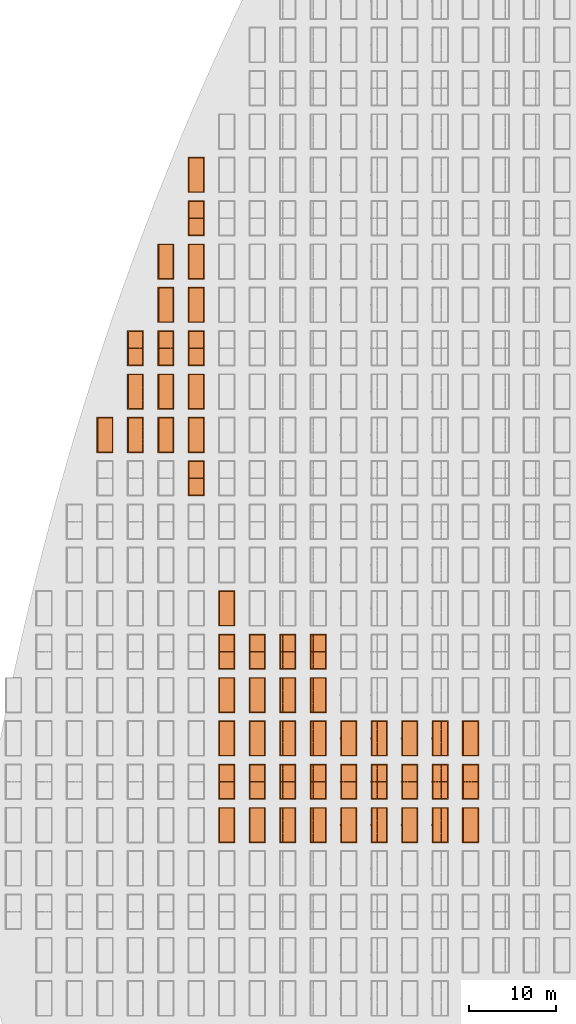
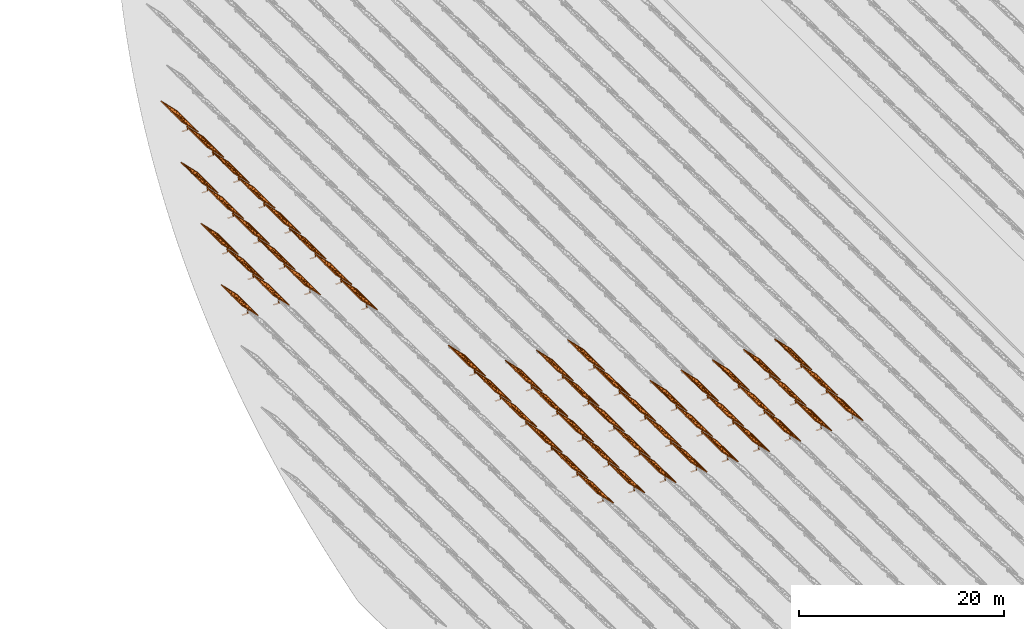
# One storey, part 22 of 39: 53 proxies.
"""IFC2X3 building model written with IfcOpenShell, lengths in millimetres."""

from ifc_helpers import new_model, entity, si_unit, converted_unit, derived_unit, direction, frame, frame_2d, origin, origin_2d_with_axis, place, context, subcontext, project, spatial, polyline, rectangle, outline, extrude, source, transform, mapped, material, material_list, element, save


model = new_model("IFC2X3")

# Units and contexts
model_context = context("Model", 3, precision=1e-06, world=origin(), true_north=direction((2.0, 6.12303176911189e-17, 1.0)))
context_of_model = context(None, 3, precision=1e-06, world=origin(), true_north=direction((2.0, 6.12303176911189e-17, 1.0)))
body_context = subcontext(model_context, "Body", "Model", "MODEL_VIEW")
ifc_project = project(units=[si_unit("LENGTHUNIT", "METRE", prefix="MILLI"), si_unit("AREAUNIT", "SQUARE_METRE", prefix="MILLI"), si_unit("VOLUMEUNIT", "CUBIC_METRE", prefix="MILLI"), converted_unit("PLANEANGLEUNIT", "DEGREE", entity("IfcRatioMeasure", 0.0174532925199433), si_unit("PLANEANGLEUNIT", "RADIAN"), dimensions=[0, 0, 0, 0, 0, 0, 0]), si_unit("MASSUNIT", "GRAM", prefix="KILO"), si_unit("TIMEUNIT", "SECOND"), si_unit("THERMODYNAMICTEMPERATUREUNIT", "KELVIN"), derived_unit("THERMALTRANSMITTANCEUNIT", [(si_unit("MASSUNIT", "GRAM", prefix="KILO"), 1), (si_unit("THERMODYNAMICTEMPERATUREUNIT", "KELVIN"), -1), (si_unit("TIMEUNIT", "SECOND"), -3)]), derived_unit("VOLUMETRICFLOWRATEUNIT", [(si_unit("LENGTHUNIT", "METRE"), 3), (si_unit("TIMEUNIT", "SECOND"), -1)])], contexts=[model_context, context_of_model])

# Site, building, storey
site_placement = place(None, origin())
site = spatial("IfcSite", under=ifc_project, at=site_placement, CompositionType="ELEMENT")
building_placement = place(site_placement, origin())
building = spatial("IfcBuilding", under=site, at=building_placement, CompositionType="ELEMENT")
storey_placement = place(building_placement, frame((0.0, 0.0, 4000.0)))
storey = spatial("IfcBuildingStorey", under=building, at=storey_placement, Name="Level 2", CompositionType="ELEMENT", Elevation=4000.0)

# Proxies
ifc_material_1 = material(Name="Stand-Steel")
ifc_material_2 = material(Name="Aluminium")
ifc_material_3 = material(Name="Glass")
ifc_material_list_1 = material_list([ifc_material_1, ifc_material_2, ifc_material_3])
shared_shape = source(origin(), body_context, "Body", "SweptSolid", [
    extrude(outline(polyline([(-629.526235435404, -220.0), (329.763117717702, -220.0), (329.763117717703, 410.0), (299.763117717703, 410.0), (299.763117717702, -190.0), (-629.526235435404, -190.0), (-629.526235435404, -220.0)])), frame((-190.00003127179, -100.0, 299.763117717707), z_axis=(0.0, 1.0, 0.0), x_axis=(0.0, 0.0, -1.0)), (0.0, 0.0, 1.0), 200.0),
    extrude(rectangle(XDim=20.0000000000001, YDim=200.0, at=frame_2d((0.0, -7.105427357601e-14), x_axis=(0.0, 1.0))), frame((-7.07109908365613, 0.0, 922.21828534124), z_axis=(-0.70710678118654, 0.0, 0.707106781186555), x_axis=(0.0, 1.0, 0.0)), (0.0, 0.0, 1.0), 2600.0),
    extrude(rectangle(XDim=24.9999999999997, YDim=24.9999999999999, at=frame_2d((2.87769807982841e-13, -9.50350909079134e-14), x_axis=(1.0, 0.0))), frame((-1449.56292018118, -1950.0, 2449.57494522722), z_axis=(0.0, 1.0, 0.0), x_axis=(-0.707106781186548, 0.0, -0.707106781186548)), (0.0, 0.0, 1.0), 3900.0),
    extrude(rectangle(XDim=24.9999999999999, YDim=25.0000000000001, at=origin_2d_with_axis()), frame((-1096.0095295879, -1950.0, 2096.02155463395), z_axis=(0.0, 1.0, 0.0), x_axis=(-0.707106781186542, 0.0, -0.707106781186553)), (0.0, 0.0, 1.0), 3900.0),
    extrude(rectangle(XDim=24.9999999999999, YDim=25.0000000000001, at=origin_2d_with_axis()), frame((-742.456138994631, -1950.0, 1742.46816404067), z_axis=(0.0, 1.0, 0.0), x_axis=(-0.707106781186542, 0.0, -0.707106781186553)), (0.0, 0.0, 1.0), 3900.0),
    extrude(rectangle(XDim=25.0, YDim=24.9999999999997, at=frame_2d((-7.19424519957101e-14, 1.19904086659517e-13), x_axis=(1.0, 0.0))), frame((-388.902748401358, -1950.0, 1388.9147734474), z_axis=(0.0, 1.0, 0.0), x_axis=(-0.707106781186545, 0.0, -0.70710678118655)), (0.0, 0.0, 1.0), 3900.0),
    extrude(rectangle(XDim=25.0000000000002, YDim=25.0, at=frame_2d((1.35891298214119e-13, 6.21724893790088e-15), x_axis=(0.0, 1.0))), frame((-35.3553703311048, 1500.0, 1035.35537033109), z_axis=(-0.707106781186544, 0.0, 0.707106781186551), x_axis=(0.0, 1.0, 0.0)), (0.0, 0.0, 1.0), 2440.0),
    extrude(rectangle(XDim=25.0000000000002, YDim=25.0, at=frame_2d((0.0, 1.77635683940025e-15), x_axis=(0.0, 1.0))), frame((-35.3553703311059, 1000.0, 1035.35537033109), z_axis=(-0.707106781186546, 0.0, 0.707106781186549), x_axis=(0.0, 1.0, 0.0)), (0.0, 0.0, 1.0), 2440.0),
    extrude(rectangle(XDim=25.0000000000002, YDim=25.0, at=frame_2d((0.0, 8.43769498715119e-14), x_axis=(0.0, 1.0))), frame((-26.5165355662756, 0.0, 1044.19420509593), z_axis=(-0.707106781186546, 0.0, 0.707106781186549), x_axis=(0.0, -1.0, 0.0)), (0.0, 0.0, 1.0), 2440.0),
    extrude(rectangle(XDim=25.0000000000002, YDim=25.0, at=frame_2d((0.0, 8.88178419700125e-16), x_axis=(0.0, 1.0))), frame((-35.3553703311065, 500.0, 1035.35537033109), z_axis=(-0.707106781186546, 0.0, 0.707106781186549), x_axis=(0.0, 1.0, 0.0)), (0.0, 0.0, 1.0), 2440.0),
    extrude(rectangle(XDim=25.0000000000002, YDim=25.0, at=frame_2d((0.0, 8.88178419700125e-16), x_axis=(0.0, 1.0))), frame((-35.3553703311086, -500.0, 1035.35537033109), z_axis=(-0.707106781186546, 0.0, 0.707106781186549), x_axis=(0.0, 1.0, 0.0)), (0.0, 0.0, 1.0), 2440.0),
    extrude(rectangle(XDim=25.0000000000002, YDim=25.0, at=frame_2d((0.0, 8.88178419700125e-16), x_axis=(0.0, 1.0))), frame((-35.3553703311095, -1000.0, 1035.35537033109), z_axis=(-0.707106781186546, 0.0, 0.707106781186549), x_axis=(0.0, 1.0, 0.0)), (0.0, 0.0, 1.0), 2440.0),
    extrude(rectangle(XDim=25.0000000000002, YDim=25.0, at=frame_2d((1.35891298214119e-13, 1.77635683940025e-15), x_axis=(0.0, 1.0))), frame((-35.3553703311107, -1500.0, 1035.35537033109), z_axis=(-0.707106781186546, 0.0, 0.707106781186549), x_axis=(0.0, 1.0, 0.0)), (0.0, 0.0, 1.0), 2440.0),
    extrude(rectangle(XDim=2400.0, YDim=11.9999999999994, at=frame_2d((-1.13686837721616e-13, 2.02948768901479e-13), x_axis=(1.0, 0.0))), frame((-883.883507754966, -1950.0, 1883.88350775495), z_axis=(0.0, 1.0, 0.0), x_axis=(0.707106781186546, 0.0, -0.707106781186549)), (0.0, 0.0, 1.0), 3900.0),
    extrude(outline(polyline([(-2050.0, -1300.0), (2050.0, -1300.0), (2050.0, 1300.0), (-2050.0, 1300.0), (-2050.0, -1300.0)]), holes=[polyline([(1950.0, -1200.0), (-1950.0, -1200.0), (-1950.0, 1200.0), (1950.0, 1200.0), (1950.0, -1200.0)])]), frame((-919.238846814293, 0.0, 1848.52816869563), z_axis=(0.707106781186554, 0.0, 0.707106781186541), x_axis=(0.0, 1.0, 0.0)), (0.0, 0.0, 1.0), 99.9999999999898),
])
proxy_1_placement = place(storey_placement, frame((-177460.32831183, 500144.680552409, 30.0)))
element("IfcBuildingElementProxy", 1, at=proxy_1_placement, inside=storey, material=ifc_material_list_1, Name="Solar Panel_4000X2500:Solar Panel_4000X2500", ObjectType="Solar Panel_4000X2500", CompositionType="ELEMENT", context=body_context, shape_type="MappedRepresentation", body=[
    mapped(shared_shape, transform((0.0, 0.0, 0.0), scale=1.0)),
])
ifc_material_list_2 = material_list([ifc_material_1, ifc_material_2, ifc_material_3])
proxy_2_placement = place(storey_placement, frame((-177460.32831183, 505144.680552409, 30.0)))
element("IfcBuildingElementProxy", 2, at=proxy_2_placement, inside=storey, material=ifc_material_list_2, Name="Solar Panel_4000X2500:Solar Panel_4000X2500", ObjectType="Solar Panel_4000X2500", CompositionType="ELEMENT", context=body_context, shape_type="MappedRepresentation", body=[
    mapped(shared_shape, transform((0.0, 0.0, 0.0), scale=1.0)),
])
ifc_material_list_3 = material_list([ifc_material_1, ifc_material_2, ifc_material_3])
proxy_3_placement = place(storey_placement, frame((-177460.32831183, 510144.680552409, 30.0)))
element("IfcBuildingElementProxy", 3, at=proxy_3_placement, inside=storey, material=ifc_material_list_3, Name="Solar Panel_4000X2500:Solar Panel_4000X2500", ObjectType="Solar Panel_4000X2500", CompositionType="ELEMENT", context=body_context, shape_type="MappedRepresentation", body=[
    mapped(shared_shape, transform((0.0, 0.0, 0.0), scale=1.0)),
])
ifc_material_list_4 = material_list([ifc_material_1, ifc_material_2, ifc_material_3])
proxy_4_placement = place(storey_placement, frame((-180975.32831183, 500144.680552409, 30.0)))
element("IfcBuildingElementProxy", 4, at=proxy_4_placement, inside=storey, material=ifc_material_list_4, Name="Solar Panel_4000X2500:Solar Panel_4000X2500", ObjectType="Solar Panel_4000X2500", CompositionType="ELEMENT", context=body_context, shape_type="MappedRepresentation", body=[
    mapped(shared_shape, transform((0.0, 0.0, 0.0), scale=1.0)),
])
ifc_material_list_5 = material_list([ifc_material_1, ifc_material_2, ifc_material_3])
proxy_5_placement = place(storey_placement, frame((-180975.32831183, 505144.680552409, 30.0)))
element("IfcBuildingElementProxy", 5, at=proxy_5_placement, inside=storey, material=ifc_material_list_5, Name="Solar Panel_4000X2500:Solar Panel_4000X2500", ObjectType="Solar Panel_4000X2500", CompositionType="ELEMENT", context=body_context, shape_type="MappedRepresentation", body=[
    mapped(shared_shape, transform((0.0, 0.0, 0.0), scale=1.0)),
])
ifc_material_list_6 = material_list([ifc_material_1, ifc_material_2, ifc_material_3])
proxy_6_placement = place(storey_placement, frame((-180975.32831183, 510144.680552409, 30.0)))
element("IfcBuildingElementProxy", 6, at=proxy_6_placement, inside=storey, material=ifc_material_list_6, Name="Solar Panel_4000X2500:Solar Panel_4000X2500", ObjectType="Solar Panel_4000X2500", CompositionType="ELEMENT", context=body_context, shape_type="MappedRepresentation", body=[
    mapped(shared_shape, transform((0.0, 0.0, 0.0), scale=1.0)),
])
ifc_material_list_7 = material_list([ifc_material_1, ifc_material_2, ifc_material_3])
proxy_7_placement = place(storey_placement, frame((-184490.32831183, 500144.680552409, 30.0)))
element("IfcBuildingElementProxy", 7, at=proxy_7_placement, inside=storey, material=ifc_material_list_7, Name="Solar Panel_4000X2500:Solar Panel_4000X2500", ObjectType="Solar Panel_4000X2500", CompositionType="ELEMENT", context=body_context, shape_type="MappedRepresentation", body=[
    mapped(shared_shape, transform((0.0, 0.0, 0.0), scale=1.0)),
])
ifc_material_list_8 = material_list([ifc_material_1, ifc_material_2, ifc_material_3])
proxy_8_placement = place(storey_placement, frame((-184490.32831183, 505144.680552409, 30.0)))
element("IfcBuildingElementProxy", 8, at=proxy_8_placement, inside=storey, material=ifc_material_list_8, Name="Solar Panel_4000X2500:Solar Panel_4000X2500", ObjectType="Solar Panel_4000X2500", CompositionType="ELEMENT", context=body_context, shape_type="MappedRepresentation", body=[
    mapped(shared_shape, transform((0.0, 0.0, 0.0), scale=1.0)),
])
ifc_material_list_9 = material_list([ifc_material_1, ifc_material_2, ifc_material_3])
proxy_9_placement = place(storey_placement, frame((-184490.32831183, 510144.680552409, 30.0)))
element("IfcBuildingElementProxy", 9, at=proxy_9_placement, inside=storey, material=ifc_material_list_9, Name="Solar Panel_4000X2500:Solar Panel_4000X2500", ObjectType="Solar Panel_4000X2500", CompositionType="ELEMENT", context=body_context, shape_type="MappedRepresentation", body=[
    mapped(shared_shape, transform((0.0, 0.0, 0.0), scale=1.0)),
])
ifc_material_list_10 = material_list([ifc_material_1, ifc_material_2, ifc_material_3])
proxy_10_placement = place(storey_placement, frame((-188005.32831183, 500144.680552409, 30.0)))
element("IfcBuildingElementProxy", 10, at=proxy_10_placement, inside=storey, material=ifc_material_list_10, Name="Solar Panel_4000X2500:Solar Panel_4000X2500", ObjectType="Solar Panel_4000X2500", CompositionType="ELEMENT", context=body_context, shape_type="MappedRepresentation", body=[
    mapped(shared_shape, transform((0.0, 0.0, 0.0), scale=1.0)),
])
ifc_material_list_11 = material_list([ifc_material_1, ifc_material_2, ifc_material_3])
proxy_11_placement = place(storey_placement, frame((-188005.32831183, 505144.680552409, 30.0)))
element("IfcBuildingElementProxy", 11, at=proxy_11_placement, inside=storey, material=ifc_material_list_11, Name="Solar Panel_4000X2500:Solar Panel_4000X2500", ObjectType="Solar Panel_4000X2500", CompositionType="ELEMENT", context=body_context, shape_type="MappedRepresentation", body=[
    mapped(shared_shape, transform((0.0, 0.0, 0.0), scale=1.0)),
])
ifc_material_list_12 = material_list([ifc_material_1, ifc_material_2, ifc_material_3])
proxy_12_placement = place(storey_placement, frame((-188005.32831183, 510144.680552409, 30.0)))
element("IfcBuildingElementProxy", 12, at=proxy_12_placement, inside=storey, material=ifc_material_list_12, Name="Solar Panel_4000X2500:Solar Panel_4000X2500", ObjectType="Solar Panel_4000X2500", CompositionType="ELEMENT", context=body_context, shape_type="MappedRepresentation", body=[
    mapped(shared_shape, transform((0.0, 0.0, 0.0), scale=1.0)),
])
ifc_material_list_13 = material_list([ifc_material_1, ifc_material_2, ifc_material_3])
proxy_13_placement = place(storey_placement, frame((-191520.32831183, 500144.680552409, 30.0)))
element("IfcBuildingElementProxy", 13, at=proxy_13_placement, inside=storey, material=ifc_material_list_13, Name="Solar Panel_4000X2500:Solar Panel_4000X2500", ObjectType="Solar Panel_4000X2500", CompositionType="ELEMENT", context=body_context, shape_type="MappedRepresentation", body=[
    mapped(shared_shape, transform((0.0, 0.0, 0.0), scale=1.0)),
])
ifc_material_list_14 = material_list([ifc_material_1, ifc_material_2, ifc_material_3])
proxy_14_placement = place(storey_placement, frame((-191520.32831183, 505144.680552409, 30.0)))
element("IfcBuildingElementProxy", 14, at=proxy_14_placement, inside=storey, material=ifc_material_list_14, Name="Solar Panel_4000X2500:Solar Panel_4000X2500", ObjectType="Solar Panel_4000X2500", CompositionType="ELEMENT", context=body_context, shape_type="MappedRepresentation", body=[
    mapped(shared_shape, transform((0.0, 0.0, 0.0), scale=1.0)),
])
ifc_material_list_15 = material_list([ifc_material_1, ifc_material_2, ifc_material_3])
proxy_15_placement = place(storey_placement, frame((-191520.32831183, 510144.680552409, 30.0)))
element("IfcBuildingElementProxy", 15, at=proxy_15_placement, inside=storey, material=ifc_material_list_15, Name="Solar Panel_4000X2500:Solar Panel_4000X2500", ObjectType="Solar Panel_4000X2500", CompositionType="ELEMENT", context=body_context, shape_type="MappedRepresentation", body=[
    mapped(shared_shape, transform((0.0, 0.0, 0.0), scale=1.0)),
])
ifc_material_list_16 = material_list([ifc_material_1, ifc_material_2, ifc_material_3])
proxy_16_placement = place(storey_placement, frame((-195035.32831183, 500144.680552409, 30.0)))
element("IfcBuildingElementProxy", 16, at=proxy_16_placement, inside=storey, material=ifc_material_list_16, Name="Solar Panel_4000X2500:Solar Panel_4000X2500", ObjectType="Solar Panel_4000X2500", CompositionType="ELEMENT", context=body_context, shape_type="MappedRepresentation", body=[
    mapped(shared_shape, transform((0.0, 0.0, 0.0), scale=1.0)),
])
ifc_material_list_17 = material_list([ifc_material_1, ifc_material_2, ifc_material_3])
proxy_17_placement = place(storey_placement, frame((-195035.32831183, 505144.680552409, 30.0)))
element("IfcBuildingElementProxy", 17, at=proxy_17_placement, inside=storey, material=ifc_material_list_17, Name="Solar Panel_4000X2500:Solar Panel_4000X2500", ObjectType="Solar Panel_4000X2500", CompositionType="ELEMENT", context=body_context, shape_type="MappedRepresentation", body=[
    mapped(shared_shape, transform((0.0, 0.0, 0.0), scale=1.0)),
])
ifc_material_list_18 = material_list([ifc_material_1, ifc_material_2, ifc_material_3])
proxy_18_placement = place(storey_placement, frame((-195035.32831183, 510144.680552409, 30.0)))
element("IfcBuildingElementProxy", 18, at=proxy_18_placement, inside=storey, material=ifc_material_list_18, Name="Solar Panel_4000X2500:Solar Panel_4000X2500", ObjectType="Solar Panel_4000X2500", CompositionType="ELEMENT", context=body_context, shape_type="MappedRepresentation", body=[
    mapped(shared_shape, transform((0.0, 0.0, 0.0), scale=1.0)),
])
ifc_material_list_19 = material_list([ifc_material_1, ifc_material_2, ifc_material_3])
proxy_19_placement = place(storey_placement, frame((-195035.32831183, 515144.680552409, 30.0)))
element("IfcBuildingElementProxy", 19, at=proxy_19_placement, inside=storey, material=ifc_material_list_19, Name="Solar Panel_4000X2500:Solar Panel_4000X2500", ObjectType="Solar Panel_4000X2500", CompositionType="ELEMENT", context=body_context, shape_type="MappedRepresentation", body=[
    mapped(shared_shape, transform((0.0, 0.0, 0.0), scale=1.0)),
])
ifc_material_list_20 = material_list([ifc_material_1, ifc_material_2, ifc_material_3])
proxy_20_placement = place(storey_placement, frame((-195035.32831183, 520144.680552409, 30.0)))
element("IfcBuildingElementProxy", 20, at=proxy_20_placement, inside=storey, material=ifc_material_list_20, Name="Solar Panel_4000X2500:Solar Panel_4000X2500", ObjectType="Solar Panel_4000X2500", CompositionType="ELEMENT", context=body_context, shape_type="MappedRepresentation", body=[
    mapped(shared_shape, transform((0.0, 0.0, 0.0), scale=1.0)),
])
ifc_material_list_21 = material_list([ifc_material_1, ifc_material_2, ifc_material_3])
proxy_21_placement = place(storey_placement, frame((-198550.32831183, 500144.680552409, 30.0)))
element("IfcBuildingElementProxy", 21, at=proxy_21_placement, inside=storey, material=ifc_material_list_21, Name="Solar Panel_4000X2500:Solar Panel_4000X2500", ObjectType="Solar Panel_4000X2500", CompositionType="ELEMENT", context=body_context, shape_type="MappedRepresentation", body=[
    mapped(shared_shape, transform((0.0, 0.0, 0.0), scale=1.0)),
])
ifc_material_list_22 = material_list([ifc_material_1, ifc_material_2, ifc_material_3])
proxy_22_placement = place(storey_placement, frame((-198550.32831183, 505144.680552409, 30.0)))
element("IfcBuildingElementProxy", 22, at=proxy_22_placement, inside=storey, material=ifc_material_list_22, Name="Solar Panel_4000X2500:Solar Panel_4000X2500", ObjectType="Solar Panel_4000X2500", CompositionType="ELEMENT", context=body_context, shape_type="MappedRepresentation", body=[
    mapped(shared_shape, transform((0.0, 0.0, 0.0), scale=1.0)),
])
ifc_material_list_23 = material_list([ifc_material_1, ifc_material_2, ifc_material_3])
proxy_23_placement = place(storey_placement, frame((-198550.32831183, 510144.680552409, 30.0)))
element("IfcBuildingElementProxy", 23, at=proxy_23_placement, inside=storey, material=ifc_material_list_23, Name="Solar Panel_4000X2500:Solar Panel_4000X2500", ObjectType="Solar Panel_4000X2500", CompositionType="ELEMENT", context=body_context, shape_type="MappedRepresentation", body=[
    mapped(shared_shape, transform((0.0, 0.0, 0.0), scale=1.0)),
])
ifc_material_list_24 = material_list([ifc_material_1, ifc_material_2, ifc_material_3])
proxy_24_placement = place(storey_placement, frame((-198550.32831183, 515144.680552409, 30.0)))
element("IfcBuildingElementProxy", 24, at=proxy_24_placement, inside=storey, material=ifc_material_list_24, Name="Solar Panel_4000X2500:Solar Panel_4000X2500", ObjectType="Solar Panel_4000X2500", CompositionType="ELEMENT", context=body_context, shape_type="MappedRepresentation", body=[
    mapped(shared_shape, transform((0.0, 0.0, 0.0), scale=1.0)),
])
ifc_material_list_25 = material_list([ifc_material_1, ifc_material_2, ifc_material_3])
proxy_25_placement = place(storey_placement, frame((-198550.32831183, 520144.680552409, 30.0)))
element("IfcBuildingElementProxy", 25, at=proxy_25_placement, inside=storey, material=ifc_material_list_25, Name="Solar Panel_4000X2500:Solar Panel_4000X2500", ObjectType="Solar Panel_4000X2500", CompositionType="ELEMENT", context=body_context, shape_type="MappedRepresentation", body=[
    mapped(shared_shape, transform((0.0, 0.0, 0.0), scale=1.0)),
])
ifc_material_list_26 = material_list([ifc_material_1, ifc_material_2, ifc_material_3])
proxy_26_placement = place(storey_placement, frame((-202065.32831183, 500144.680552409, 30.0)))
element("IfcBuildingElementProxy", 26, at=proxy_26_placement, inside=storey, material=ifc_material_list_26, Name="Solar Panel_4000X2500:Solar Panel_4000X2500", ObjectType="Solar Panel_4000X2500", CompositionType="ELEMENT", context=body_context, shape_type="MappedRepresentation", body=[
    mapped(shared_shape, transform((0.0, 0.0, 0.0), scale=1.0)),
])
ifc_material_list_27 = material_list([ifc_material_1, ifc_material_2, ifc_material_3])
proxy_27_placement = place(storey_placement, frame((-202065.32831183, 505144.680552409, 30.0)))
element("IfcBuildingElementProxy", 27, at=proxy_27_placement, inside=storey, material=ifc_material_list_27, Name="Solar Panel_4000X2500:Solar Panel_4000X2500", ObjectType="Solar Panel_4000X2500", CompositionType="ELEMENT", context=body_context, shape_type="MappedRepresentation", body=[
    mapped(shared_shape, transform((0.0, 0.0, 0.0), scale=1.0)),
])
ifc_material_list_28 = material_list([ifc_material_1, ifc_material_2, ifc_material_3])
proxy_28_placement = place(storey_placement, frame((-202065.32831183, 510144.680552409, 30.0)))
element("IfcBuildingElementProxy", 28, at=proxy_28_placement, inside=storey, material=ifc_material_list_28, Name="Solar Panel_4000X2500:Solar Panel_4000X2500", ObjectType="Solar Panel_4000X2500", CompositionType="ELEMENT", context=body_context, shape_type="MappedRepresentation", body=[
    mapped(shared_shape, transform((0.0, 0.0, 0.0), scale=1.0)),
])
ifc_material_list_29 = material_list([ifc_material_1, ifc_material_2, ifc_material_3])
proxy_29_placement = place(storey_placement, frame((-202065.32831183, 515144.680552409, 30.0)))
element("IfcBuildingElementProxy", 29, at=proxy_29_placement, inside=storey, material=ifc_material_list_29, Name="Solar Panel_4000X2500:Solar Panel_4000X2500", ObjectType="Solar Panel_4000X2500", CompositionType="ELEMENT", context=body_context, shape_type="MappedRepresentation", body=[
    mapped(shared_shape, transform((0.0, 0.0, 0.0), scale=1.0)),
])
ifc_material_list_30 = material_list([ifc_material_1, ifc_material_2, ifc_material_3])
proxy_30_placement = place(storey_placement, frame((-202065.32831183, 520144.680552409, 30.0)))
element("IfcBuildingElementProxy", 30, at=proxy_30_placement, inside=storey, material=ifc_material_list_30, Name="Solar Panel_4000X2500:Solar Panel_4000X2500", ObjectType="Solar Panel_4000X2500", CompositionType="ELEMENT", context=body_context, shape_type="MappedRepresentation", body=[
    mapped(shared_shape, transform((0.0, 0.0, 0.0), scale=1.0)),
])
ifc_material_list_31 = material_list([ifc_material_1, ifc_material_2, ifc_material_3])
proxy_31_placement = place(storey_placement, frame((-205580.32831183, 500144.680552409, 30.0)))
element("IfcBuildingElementProxy", 31, at=proxy_31_placement, inside=storey, material=ifc_material_list_31, Name="Solar Panel_4000X2500:Solar Panel_4000X2500", ObjectType="Solar Panel_4000X2500", CompositionType="ELEMENT", context=body_context, shape_type="MappedRepresentation", body=[
    mapped(shared_shape, transform((0.0, 0.0, 0.0), scale=1.0)),
])
ifc_material_list_32 = material_list([ifc_material_1, ifc_material_2, ifc_material_3])
proxy_32_placement = place(storey_placement, frame((-205580.32831183, 505144.680552409, 30.0)))
element("IfcBuildingElementProxy", 32, at=proxy_32_placement, inside=storey, material=ifc_material_list_32, Name="Solar Panel_4000X2500:Solar Panel_4000X2500", ObjectType="Solar Panel_4000X2500", CompositionType="ELEMENT", context=body_context, shape_type="MappedRepresentation", body=[
    mapped(shared_shape, transform((0.0, 0.0, 0.0), scale=1.0)),
])
ifc_material_list_33 = material_list([ifc_material_1, ifc_material_2, ifc_material_3])
proxy_33_placement = place(storey_placement, frame((-205580.32831183, 510144.680552409, 30.0)))
element("IfcBuildingElementProxy", 33, at=proxy_33_placement, inside=storey, material=ifc_material_list_33, Name="Solar Panel_4000X2500:Solar Panel_4000X2500", ObjectType="Solar Panel_4000X2500", CompositionType="ELEMENT", context=body_context, shape_type="MappedRepresentation", body=[
    mapped(shared_shape, transform((0.0, 0.0, 0.0), scale=1.0)),
])
ifc_material_list_34 = material_list([ifc_material_1, ifc_material_2, ifc_material_3])
proxy_34_placement = place(storey_placement, frame((-205580.32831183, 515144.680552409, 30.0)))
element("IfcBuildingElementProxy", 34, at=proxy_34_placement, inside=storey, material=ifc_material_list_34, Name="Solar Panel_4000X2500:Solar Panel_4000X2500", ObjectType="Solar Panel_4000X2500", CompositionType="ELEMENT", context=body_context, shape_type="MappedRepresentation", body=[
    mapped(shared_shape, transform((0.0, 0.0, 0.0), scale=1.0)),
])
ifc_material_list_35 = material_list([ifc_material_1, ifc_material_2, ifc_material_3])
proxy_35_placement = place(storey_placement, frame((-205580.32831183, 520144.680552409, 30.0)))
element("IfcBuildingElementProxy", 35, at=proxy_35_placement, inside=storey, material=ifc_material_list_35, Name="Solar Panel_4000X2500:Solar Panel_4000X2500", ObjectType="Solar Panel_4000X2500", CompositionType="ELEMENT", context=body_context, shape_type="MappedRepresentation", body=[
    mapped(shared_shape, transform((0.0, 0.0, 0.0), scale=1.0)),
])
ifc_material_list_36 = material_list([ifc_material_1, ifc_material_2, ifc_material_3])
proxy_36_placement = place(storey_placement, frame((-205580.32831183, 525144.680552409, 30.0)))
element("IfcBuildingElementProxy", 36, at=proxy_36_placement, inside=storey, material=ifc_material_list_36, Name="Solar Panel_4000X2500:Solar Panel_4000X2500", ObjectType="Solar Panel_4000X2500", CompositionType="ELEMENT", context=body_context, shape_type="MappedRepresentation", body=[
    mapped(shared_shape, transform((0.0, 0.0, 0.0), scale=1.0)),
])
ifc_material_list_37 = material_list([ifc_material_1, ifc_material_2, ifc_material_3])
proxy_37_placement = place(storey_placement, frame((-209095.328311831, 540144.680552409, 30.0)))
element("IfcBuildingElementProxy", 37, at=proxy_37_placement, inside=storey, material=ifc_material_list_37, Name="Solar Panel_4000X2500:Solar Panel_4000X2500", ObjectType="Solar Panel_4000X2500", CompositionType="ELEMENT", context=body_context, shape_type="MappedRepresentation", body=[
    mapped(shared_shape, transform((0.0, 0.0, 0.0), scale=1.0)),
])
ifc_material_list_38 = material_list([ifc_material_1, ifc_material_2, ifc_material_3])
proxy_38_placement = place(storey_placement, frame((-209095.328311831, 545144.680552408, 30.0)))
element("IfcBuildingElementProxy", 38, at=proxy_38_placement, inside=storey, material=ifc_material_list_38, Name="Solar Panel_4000X2500:Solar Panel_4000X2500", ObjectType="Solar Panel_4000X2500", CompositionType="ELEMENT", context=body_context, shape_type="MappedRepresentation", body=[
    mapped(shared_shape, transform((0.0, 0.0, 0.0), scale=1.0)),
])
ifc_material_list_39 = material_list([ifc_material_1, ifc_material_2, ifc_material_3])
proxy_39_placement = place(storey_placement, frame((-209095.328311831, 550144.680552408, 30.0)))
element("IfcBuildingElementProxy", 39, at=proxy_39_placement, inside=storey, material=ifc_material_list_39, Name="Solar Panel_4000X2500:Solar Panel_4000X2500", ObjectType="Solar Panel_4000X2500", CompositionType="ELEMENT", context=body_context, shape_type="MappedRepresentation", body=[
    mapped(shared_shape, transform((0.0, 0.0, 0.0), scale=1.0)),
])
ifc_material_list_40 = material_list([ifc_material_1, ifc_material_2, ifc_material_3])
proxy_40_placement = place(storey_placement, frame((-209095.328311831, 555144.680552408, 30.0)))
element("IfcBuildingElementProxy", 40, at=proxy_40_placement, inside=storey, material=ifc_material_list_40, Name="Solar Panel_4000X2500:Solar Panel_4000X2500", ObjectType="Solar Panel_4000X2500", CompositionType="ELEMENT", context=body_context, shape_type="MappedRepresentation", body=[
    mapped(shared_shape, transform((0.0, 0.0, 0.0), scale=1.0)),
])
ifc_material_list_41 = material_list([ifc_material_1, ifc_material_2, ifc_material_3])
proxy_41_placement = place(storey_placement, frame((-209095.328311831, 560144.680552408, 30.0)))
element("IfcBuildingElementProxy", 41, at=proxy_41_placement, inside=storey, material=ifc_material_list_41, Name="Solar Panel_4000X2500:Solar Panel_4000X2500", ObjectType="Solar Panel_4000X2500", CompositionType="ELEMENT", context=body_context, shape_type="MappedRepresentation", body=[
    mapped(shared_shape, transform((0.0, 0.0, 0.0), scale=1.0)),
])
ifc_material_list_42 = material_list([ifc_material_1, ifc_material_2, ifc_material_3])
proxy_42_placement = place(storey_placement, frame((-209095.328311831, 565144.680552408, 30.0)))
element("IfcBuildingElementProxy", 42, at=proxy_42_placement, inside=storey, material=ifc_material_list_42, Name="Solar Panel_4000X2500:Solar Panel_4000X2500", ObjectType="Solar Panel_4000X2500", CompositionType="ELEMENT", context=body_context, shape_type="MappedRepresentation", body=[
    mapped(shared_shape, transform((0.0, 0.0, 0.0), scale=1.0)),
])
ifc_material_list_43 = material_list([ifc_material_1, ifc_material_2, ifc_material_3])
proxy_43_placement = place(storey_placement, frame((-209095.328311831, 570144.680552408, 30.0)))
element("IfcBuildingElementProxy", 43, at=proxy_43_placement, inside=storey, material=ifc_material_list_43, Name="Solar Panel_4000X2500:Solar Panel_4000X2500", ObjectType="Solar Panel_4000X2500", CompositionType="ELEMENT", context=body_context, shape_type="MappedRepresentation", body=[
    mapped(shared_shape, transform((0.0, 0.0, 0.0), scale=1.0)),
])
ifc_material_list_44 = material_list([ifc_material_1, ifc_material_2, ifc_material_3])
proxy_44_placement = place(storey_placement, frame((-212610.328311831, 545144.680552408, 30.0)))
element("IfcBuildingElementProxy", 44, at=proxy_44_placement, inside=storey, material=ifc_material_list_44, Name="Solar Panel_4000X2500:Solar Panel_4000X2500", ObjectType="Solar Panel_4000X2500", CompositionType="ELEMENT", context=body_context, shape_type="MappedRepresentation", body=[
    mapped(shared_shape, transform((0.0, 0.0, 0.0), scale=1.0)),
])
ifc_material_list_45 = material_list([ifc_material_1, ifc_material_2, ifc_material_3])
proxy_45_placement = place(storey_placement, frame((-212610.328311831, 550144.680552408, 30.0)))
element("IfcBuildingElementProxy", 45, at=proxy_45_placement, inside=storey, material=ifc_material_list_45, Name="Solar Panel_4000X2500:Solar Panel_4000X2500", ObjectType="Solar Panel_4000X2500", CompositionType="ELEMENT", context=body_context, shape_type="MappedRepresentation", body=[
    mapped(shared_shape, transform((0.0, 0.0, 0.0), scale=1.0)),
])
ifc_material_list_46 = material_list([ifc_material_1, ifc_material_2, ifc_material_3])
proxy_46_placement = place(storey_placement, frame((-212610.328311831, 555144.680552408, 30.0)))
element("IfcBuildingElementProxy", 46, at=proxy_46_placement, inside=storey, material=ifc_material_list_46, Name="Solar Panel_4000X2500:Solar Panel_4000X2500", ObjectType="Solar Panel_4000X2500", CompositionType="ELEMENT", context=body_context, shape_type="MappedRepresentation", body=[
    mapped(shared_shape, transform((0.0, 0.0, 0.0), scale=1.0)),
])
ifc_material_list_47 = material_list([ifc_material_1, ifc_material_2, ifc_material_3])
proxy_47_placement = place(storey_placement, frame((-212610.328311831, 560144.680552408, 30.0)))
element("IfcBuildingElementProxy", 47, at=proxy_47_placement, inside=storey, material=ifc_material_list_47, Name="Solar Panel_4000X2500:Solar Panel_4000X2500", ObjectType="Solar Panel_4000X2500", CompositionType="ELEMENT", context=body_context, shape_type="MappedRepresentation", body=[
    mapped(shared_shape, transform((0.0, 0.0, 0.0), scale=1.0)),
])
ifc_material_list_48 = material_list([ifc_material_1, ifc_material_2, ifc_material_3])
proxy_48_placement = place(storey_placement, frame((-216125.328311831, 545144.680552408, 30.0)))
element("IfcBuildingElementProxy", 48, at=proxy_48_placement, inside=storey, material=ifc_material_list_48, Name="Solar Panel_4000X2500:Solar Panel_4000X2500", ObjectType="Solar Panel_4000X2500", CompositionType="ELEMENT", context=body_context, shape_type="MappedRepresentation", body=[
    mapped(shared_shape, transform((0.0, 0.0, 0.0), scale=1.0)),
])
ifc_material_list_49 = material_list([ifc_material_1, ifc_material_2, ifc_material_3])
proxy_49_placement = place(storey_placement, frame((-216125.328311831, 550144.680552408, 30.0)))
element("IfcBuildingElementProxy", 49, at=proxy_49_placement, inside=storey, material=ifc_material_list_49, Name="Solar Panel_4000X2500:Solar Panel_4000X2500", ObjectType="Solar Panel_4000X2500", CompositionType="ELEMENT", context=body_context, shape_type="MappedRepresentation", body=[
    mapped(shared_shape, transform((0.0, 0.0, 0.0), scale=1.0)),
])
ifc_material_list_50 = material_list([ifc_material_1, ifc_material_2, ifc_material_3])
proxy_50_placement = place(storey_placement, frame((-219640.328311831, 545144.680552408, 30.0)))
element("IfcBuildingElementProxy", 50, at=proxy_50_placement, inside=storey, material=ifc_material_list_50, Name="Solar Panel_4000X2500:Solar Panel_4000X2500", ObjectType="Solar Panel_4000X2500", CompositionType="ELEMENT", context=body_context, shape_type="MappedRepresentation", body=[
    mapped(shared_shape, transform((0.0, 0.0, 0.0), scale=1.0)),
])
ifc_material_list_51 = material_list([ifc_material_1, ifc_material_2, ifc_material_3])
proxy_51_placement = place(storey_placement, frame((-216125.328311831, 555144.680552408, 30.0)))
element("IfcBuildingElementProxy", 51, at=proxy_51_placement, inside=storey, material=ifc_material_list_51, Name="Solar Panel_4000X2500:Solar Panel_4000X2500", ObjectType="Solar Panel_4000X2500", CompositionType="ELEMENT", context=body_context, shape_type="MappedRepresentation", body=[
    mapped(shared_shape, transform((0.0, 0.0, 0.0), scale=1.0)),
])
ifc_material_list_52 = material_list([ifc_material_1, ifc_material_2, ifc_material_3])
proxy_52_placement = place(storey_placement, frame((-212610.328311831, 565144.680552408, 30.0)))
element("IfcBuildingElementProxy", 52, at=proxy_52_placement, inside=storey, material=ifc_material_list_52, Name="Solar Panel_4000X2500:Solar Panel_4000X2500", ObjectType="Solar Panel_4000X2500", CompositionType="ELEMENT", context=body_context, shape_type="MappedRepresentation", body=[
    mapped(shared_shape, transform((0.0, 0.0, 0.0), scale=1.0)),
])
ifc_material_list_53 = material_list([ifc_material_1, ifc_material_2, ifc_material_3])
proxy_53_placement = place(storey_placement, frame((-209095.328311831, 575144.680552408, 30.0)))
element("IfcBuildingElementProxy", 53, at=proxy_53_placement, inside=storey, material=ifc_material_list_53, Name="Solar Panel_4000X2500:Solar Panel_4000X2500", ObjectType="Solar Panel_4000X2500", CompositionType="ELEMENT", context=body_context, shape_type="MappedRepresentation", body=[
    mapped(shared_shape, transform((0.0, 0.0, 0.0), scale=1.0)),
])

save(model, "model.ifc")
